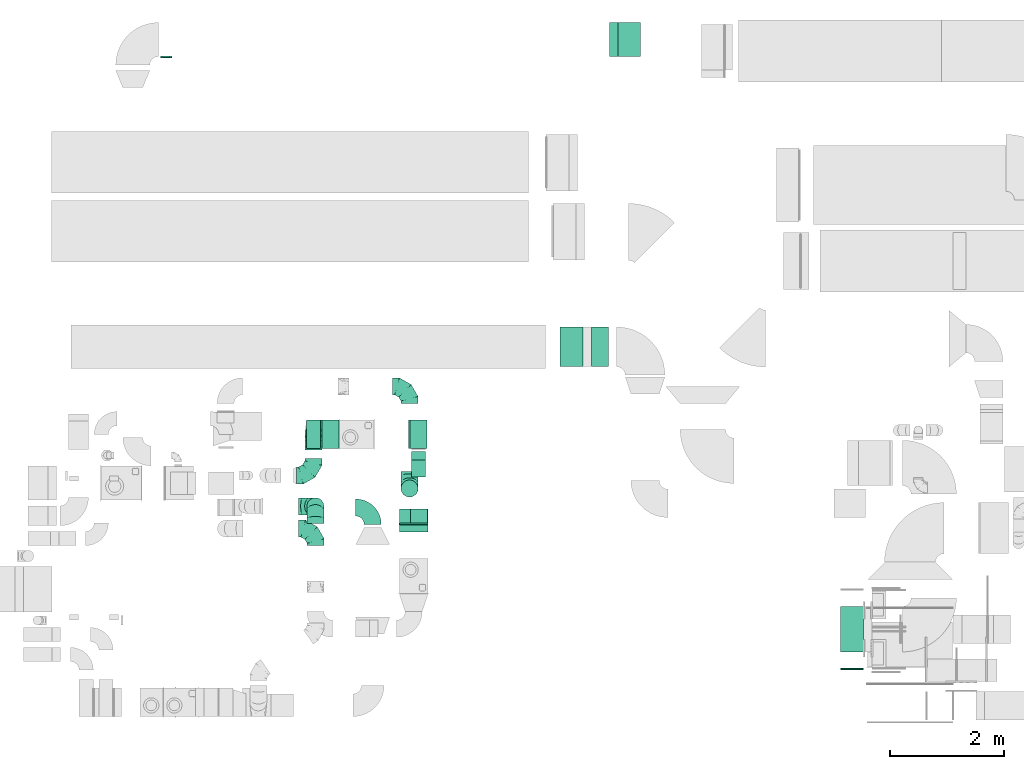
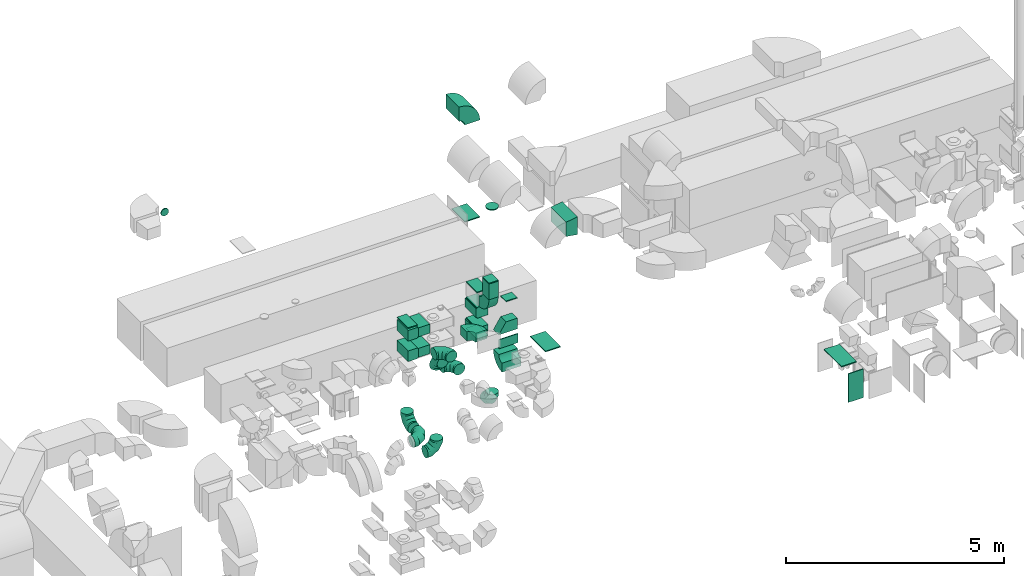
# One storey, part 12 of 59: 31 flow fittings, 1 flow segment.
"""IFC2X3 building model written with IfcOpenShell, lengths in millimetres."""

from ifc_helpers import new_model, entity, si_unit, converted_unit, derived_unit, direction, frame, frame_2d, origin, origin_2d_with_axis, place, context, subcontext, project, spatial, polyline, circle_curve, parameter, trimmed, segment, composite_curve, rectangle, circle, outline, extrude, faceted_brep, source, transform, mapped, material, type_object, type_shapes, element, save


model = new_model("IFC2X3")

# Units and contexts
model_context = context("Model", 3, precision=0.01, world=origin(), true_north=direction((6.12303176911189e-17, 1.0)))
body_context = subcontext(model_context, "Body", "Model", "MODEL_VIEW")
ifc_project = project(units=[si_unit("LENGTHUNIT", "METRE", prefix="MILLI"), si_unit("AREAUNIT", "SQUARE_METRE"), si_unit("VOLUMEUNIT", "CUBIC_METRE"), converted_unit("PLANEANGLEUNIT", "DEGREE", entity("IfcRatioMeasure", 0.0174532925199433), si_unit("PLANEANGLEUNIT", "RADIAN"), dimensions=[0, 0, 0, 0, 0, 0, 0]), si_unit("MASSUNIT", "GRAM", prefix="KILO"), derived_unit("MASSDENSITYUNIT", [(si_unit("MASSUNIT", "GRAM", prefix="KILO"), 1), (si_unit("LENGTHUNIT", "METRE"), -3)]), derived_unit("MOMENTOFINERTIAUNIT", [(si_unit("LENGTHUNIT", "METRE"), 4)]), si_unit("TIMEUNIT", "SECOND"), si_unit("FREQUENCYUNIT", "HERTZ"), si_unit("THERMODYNAMICTEMPERATUREUNIT", "DEGREE_CELSIUS"), derived_unit("THERMALTRANSMITTANCEUNIT", [(si_unit("MASSUNIT", "GRAM", prefix="KILO"), 1), (si_unit("THERMODYNAMICTEMPERATUREUNIT", "KELVIN"), -1), (si_unit("TIMEUNIT", "SECOND"), -3)]), derived_unit("VOLUMETRICFLOWRATEUNIT", [(si_unit("LENGTHUNIT", "METRE"), 3), (si_unit("TIMEUNIT", "SECOND"), -1)]), derived_unit("MASSFLOWRATEUNIT", [(si_unit("MASSUNIT", "GRAM", prefix="KILO"), 1), (si_unit("TIMEUNIT", "SECOND"), -1)]), derived_unit("ROTATIONALFREQUENCYUNIT", [(si_unit("TIMEUNIT", "SECOND"), -1)]), si_unit("ELECTRICCURRENTUNIT", "AMPERE"), si_unit("ELECTRICVOLTAGEUNIT", "VOLT"), si_unit("POWERUNIT", "WATT"), si_unit("FORCEUNIT", "NEWTON", prefix="KILO"), si_unit("ILLUMINANCEUNIT", "LUX"), si_unit("LUMINOUSFLUXUNIT", "LUMEN"), si_unit("LUMINOUSINTENSITYUNIT", "CANDELA"), derived_unit("USERDEFINED", [(si_unit("MASSUNIT", "GRAM", prefix="KILO"), -1), (si_unit("LENGTHUNIT", "METRE"), -2), (si_unit("TIMEUNIT", "SECOND"), 3), (si_unit("LUMINOUSFLUXUNIT", "LUMEN"), 1)]), derived_unit("LINEARVELOCITYUNIT", [(si_unit("LENGTHUNIT", "METRE"), 1), (si_unit("TIMEUNIT", "SECOND"), -1)]), si_unit("PRESSUREUNIT", "PASCAL"), derived_unit("USERDEFINED", [(si_unit("LENGTHUNIT", "METRE"), -2), (si_unit("MASSUNIT", "GRAM", prefix="KILO"), 1), (si_unit("TIMEUNIT", "SECOND"), -2)]), derived_unit("LINEARFORCEUNIT", [(si_unit("MASSUNIT", "GRAM", prefix="KILO"), 1), (si_unit("LENGTHUNIT", "METRE"), 1), (si_unit("TIMEUNIT", "SECOND"), -2), (si_unit("LENGTHUNIT", "METRE"), -1)]), derived_unit("PLANARFORCEUNIT", [(si_unit("MASSUNIT", "GRAM", prefix="KILO"), 1), (si_unit("LENGTHUNIT", "METRE"), 1), (si_unit("TIMEUNIT", "SECOND"), -2), (si_unit("LENGTHUNIT", "METRE"), -2)])], contexts=[model_context])

# Site, building, storey
site_placement = place(None, origin())
site = spatial("IfcSite", under=ifc_project, at=site_placement, CompositionType="ELEMENT")
building_placement = place(site_placement, origin())
building = spatial("IfcBuilding", under=site, at=building_placement, CompositionType="ELEMENT")
storey_placement = place(building_placement, frame((0.0, 0.0, 28200.0)))
storey = spatial("IfcBuildingStorey", under=building, at=storey_placement, CompositionType="ELEMENT", Elevation=28200.0)

# Flow segment
duct_segment_type = type_object("IfcDuctSegmentType", PredefinedType="NOTDEFINED")
flow_segment_placement = place(storey_placement, frame((34404.03, 12149.6, 3765.0)))
element("IfcFlowSegment", 1, at=flow_segment_placement, inside=storey, type_object=duct_segment_type, context=body_context, shape_type="SweptSolid", body=[
    extrude(rectangle(XDim=300.000000000001, YDim=249.999999999999, at=origin_2d_with_axis()), frame((125.0, 150.0, 0.0), z_axis=(0.0, 0.0, 1.0), x_axis=(0.0, 1.0, 0.0)), (0.0, 0.0, 1.0), 440.000024999958),
])

# Flow fittings
ifc_material = material()
duct_fitting_type_1 = type_object("IfcDuctFittingType", PredefinedType="NOTDEFINED", material=ifc_material)
shared_shape_1 = source(origin(), body_context, "Body", "SweptSolid", [
    extrude(rectangle(XDim=24.9999999999999, YDim=400.0, at=origin_2d_with_axis()), frame((12.5, 0.0, -300.0)), (0.0, 0.0, 1.0), 600.0),
])
type_shapes(duct_fitting_type_1, [shared_shape_1])
flow_fitting_1_placement = place(storey_placement, frame((38240.11, 19854.6, 196.21), z_axis=(0.0, -1.0, 0.0), x_axis=(0.0, 0.0, -1.0)))
element("IfcFlowFitting", 2, at=flow_fitting_1_placement, inside=storey, type_object=duct_fitting_type_1, material=ifc_material, context=body_context, shape_type="MappedRepresentation", body=[
    mapped(shared_shape_1, transform((0.0, 0.0, 0.0), scale=1.0)),
])
duct_fitting_type_2 = type_object("IfcDuctFittingType", PredefinedType="NOTDEFINED", material=ifc_material)
shared_shape_2 = source(origin(), body_context, "Body", "SweptSolid", [
    extrude(rectangle(XDim=24.9999999999999, YDim=400.0, at=origin_2d_with_axis()), frame((12.5, 0.0, -350.0)), (0.0, 0.0, 1.0), 700.0),
])
type_shapes(duct_fitting_type_2, [shared_shape_2])
flow_fitting_2_placement = place(storey_placement, frame((37223.99, 14444.6, 230.0), z_axis=(0.0, -1.0, 0.0), x_axis=(0.0, 0.0, -1.0)))
element("IfcFlowFitting", 3, at=flow_fitting_2_placement, inside=storey, type_object=duct_fitting_type_2, material=ifc_material, context=body_context, shape_type="MappedRepresentation", body=[
    mapped(shared_shape_2, transform((0.0, 0.0, 0.0), scale=1.0)),
])
duct_fitting_type_3 = type_object("IfcDuctFittingType", PredefinedType="NOTDEFINED", material=ifc_material)
shared_shape_3 = source(origin(), body_context, "Body", "SweptSolid", [
    extrude(outline(polyline([(-115.08, -221.94), (189.06, -221.94), (106.86, 271.26), (-180.84, 172.62), (-115.08, -221.94)])), frame((150.0, -350.0, 0.0), z_axis=(0.0, 1.0, 0.0), x_axis=(0.986393923832159, 0.0, 0.164398987305264)), (0.0, 0.0, 1.0), 700.0),
])
type_shapes(duct_fitting_type_3, [shared_shape_3])
flow_fitting_3_placement = place(storey_placement, frame((37573.99, 14444.6, 3450.0)))
element("IfcFlowFitting", 4, at=flow_fitting_3_placement, inside=storey, type_object=duct_fitting_type_3, material=ifc_material, context=body_context, shape_type="MappedRepresentation", body=[
    mapped(shared_shape_3, transform((0.0, 0.0, 0.0), scale=1.0)),
])
duct_fitting_type_4 = type_object("IfcDuctFittingType", PredefinedType="NOTDEFINED", material=ifc_material)
shared_shape_4 = source(origin(), body_context, "Body", "SweptSolid", [
    extrude(rectangle(XDim=26.0960000000177, YDim=250.0, at=origin_2d_with_axis()), frame((6.95, 0.0, -250.0)), (0.0, 0.0, 1.0), 500.0),
])
type_shapes(duct_fitting_type_4, [shared_shape_4])
flow_fitting_4_placement = place(storey_placement, frame((34445.98, 11335.54, 3100.0), z_axis=(-1.0, 0.0, 0.0), x_axis=(0.0, -1.0, 0.0)))
element("IfcFlowFitting", 5, at=flow_fitting_4_placement, inside=storey, type_object=duct_fitting_type_4, material=ifc_material, context=body_context, shape_type="MappedRepresentation", body=[
    mapped(shared_shape_4, transform((0.0, 0.0, 0.0), scale=1.0)),
])
duct_fitting_type_5 = type_object("IfcDuctFittingType", PredefinedType="NOTDEFINED", material=ifc_material)
shared_shape_5 = source(origin(), body_context, "Body", "SweptSolid", [
    extrude(outline(polyline([(-154.94, -199.94), (145.15, -199.94), (152.49, 99.97), (-142.71, 299.91), (-154.94, -199.94)])), frame((150.0, -125.0, 46.33), z_axis=(0.0, 1.0, 0.0), x_axis=(0.999701032994285, 0.0, -0.0244508615422689)), (0.0, 0.0, 1.0), 250.0),
])
type_shapes(duct_fitting_type_5, [shared_shape_5])
flow_fitting_5_placement = place(storey_placement, frame((34445.98, 11460.54, 3349.26), z_axis=(1.0, 0.0, 0.0), x_axis=(0.0, 0.0, 1.0)))
element("IfcFlowFitting", 6, at=flow_fitting_5_placement, inside=storey, type_object=duct_fitting_type_5, material=ifc_material, context=body_context, shape_type="MappedRepresentation", body=[
    mapped(shared_shape_5, transform((0.0, 0.0, 0.0), scale=1.0)),
])
duct_fitting_type_6 = type_object("IfcDuctFittingType", PredefinedType="NOTDEFINED", material=ifc_material)
shared_shape_6 = source(origin(), body_context, "Body", "SweptSolid", [
    extrude(rectangle(XDim=24.9999999999999, YDim=400.0, at=origin_2d_with_axis()), frame((12.5, 0.0, -400.0)), (0.0, 0.0, 1.0), 800.0),
])
type_shapes(duct_fitting_type_6, [shared_shape_6])
flow_fitting_6_placement = place(storey_placement, frame((42165.03, 8785.16, 700.0), z_axis=(0.0, 0.0, 1.0), x_axis=(0.0, -1.0, 0.0)))
element("IfcFlowFitting", 7, at=flow_fitting_6_placement, inside=storey, type_object=duct_fitting_type_6, material=ifc_material, context=body_context, shape_type="MappedRepresentation", body=[
    mapped(shared_shape_6, transform((0.0, 0.0, 0.0), scale=1.0)),
])
duct_fitting_type_7 = type_object("IfcDuctFittingType", PredefinedType="NOTDEFINED", material=ifc_material)
shared_shape_7 = source(origin(), body_context, "Body", "SweptSolid", [
    extrude(rectangle(XDim=24.9999999999999, YDim=250.0, at=origin_2d_with_axis()), frame((12.5, 0.0, -250.0)), (0.0, 0.0, 1.0), 500.0),
])
type_shapes(duct_fitting_type_7, [shared_shape_7])
flow_fitting_7_placement = place(storey_placement, frame((32680.82, 12904.98, 3300.0), z_axis=(0.0, 1.0, 0.0), x_axis=(0.0, 0.0, 1.0)))
element("IfcFlowFitting", 8, at=flow_fitting_7_placement, inside=storey, type_object=duct_fitting_type_7, material=ifc_material, context=body_context, shape_type="MappedRepresentation", body=[
    mapped(shared_shape_7, transform((0.0, 0.0, 0.0), scale=1.0)),
])
duct_fitting_type_8 = type_object("IfcDuctFittingType", PredefinedType="NOTDEFINED", material=ifc_material)
shared_shape_8 = source(origin(), body_context, "Body", "SweptSolid", [
    extrude(outline(polyline([(-150.0, 56.25), (-150.0, -193.75), (150.0, -193.75), (150.0, 56.25), (125.0, 56.25), (125.0, 81.25), (-125.0, 81.25), (-125.0, 56.25), (-150.0, 56.25)])), frame((0.0, -68.75, -250.0), z_axis=(0.0, 0.0, -1.0), x_axis=(1.0, 0.0, 0.0)), (0.0, 0.0, -1.0), 500.0),
])
type_shapes(duct_fitting_type_8, [shared_shape_8])
for number, where, z_axis, x_axis in (
    (9, (32680.82, 12904.98, 2525.0), (0.0, 1.0, 0.0), (0.0, 0.0, -1.0)),
    (10, (32680.82, 12904.98, 3100.0), (0.0, 1.0, 0.0), (0.0, 0.0, -1.0)),
):
    element("IfcFlowFitting", number, at=place(storey_placement, frame(where, z_axis=z_axis, x_axis=x_axis)), inside=storey, type_object=duct_fitting_type_8, material=ifc_material, context=body_context, shape_type="MappedRepresentation", body=[
        mapped(shared_shape_8, transform((0.0, 0.0, 0.0), scale=1.0)),
    ])
duct_fitting_type_9 = type_object("IfcDuctFittingType", PredefinedType="NOTDEFINED", material=ifc_material)
shared_shape_9 = source(origin(), body_context, "Body", "SweptSolid", [
    extrude(rectangle(XDim=300.0, YDim=500.0, at=origin_2d_with_axis()), frame((150.0, 0.0, -125.0)), (0.0, 0.0, 1.0), 250.0),
])
type_shapes(duct_fitting_type_9, [shared_shape_9])
for number, where in (
    (11, (32830.82, 12904.98, 3100.0)),
    (12, (32830.82, 12904.98, 2525.0)),
):
    element("IfcFlowFitting", number, at=place(storey_placement, frame(where)), inside=storey, type_object=duct_fitting_type_9, material=ifc_material, context=body_context, shape_type="MappedRepresentation", body=[
        mapped(shared_shape_9, transform((0.0, 0.0, 0.0), scale=1.0)),
    ])
duct_fitting_type_10 = type_object("IfcDuctFittingType", PredefinedType="NOTDEFINED", material=ifc_material)
shared_shape_10 = source(origin(), body_context, "Body", "SweptSolid", [
    extrude(outline(polyline([(-150.0, 68.75), (-150.0, -231.25), (150.0, -231.25), (150.0, 68.75), (125.0, 68.75), (125.0, 93.75), (-125.0, 93.75), (-125.0, 68.75), (-150.0, 68.75)])), frame((0.0, -81.25, -250.0), z_axis=(0.0, 0.0, -1.0), x_axis=(1.0, 0.0, 0.0)), (0.0, 0.0, -1.0), 500.0),
])
type_shapes(duct_fitting_type_10, [shared_shape_10])
for number, where, z_axis, x_axis in (
    (13, (34529.03, 12904.98, 2525.0), (0.0, 1.0, 0.0), (0.0, 0.0, 1.0)),
    (14, (34529.03, 12904.98, 3100.0), (0.0, 1.0, 0.0), (0.0, 0.0, 1.0)),
):
    element("IfcFlowFitting", number, at=place(storey_placement, frame(where, z_axis=z_axis, x_axis=x_axis)), inside=storey, type_object=duct_fitting_type_10, material=ifc_material, context=body_context, shape_type="MappedRepresentation", body=[
        mapped(shared_shape_10, transform((0.0, 0.0, 0.0), scale=1.0)),
    ])
duct_fitting_type_11 = type_object("IfcDuctFittingType", PredefinedType="NOTDEFINED", material=ifc_material)
shared_shape_11 = source(origin(), body_context, "Body", "SweptSolid", [
    extrude(rectangle(XDim=24.9999999999999, YDim=300.0, at=origin_2d_with_axis()), frame((12.5, 0.0, -250.0)), (0.0, 0.0, 1.0), 500.0),
])
type_shapes(duct_fitting_type_11, [shared_shape_11])
for number, where, z_axis, x_axis in (
    (15, (34529.03, 12904.98, 2375.0), (0.0, 1.0, 0.0), (0.0, 0.0, -1.0)),
    (16, (34529.03, 12904.98, 3655.0), (0.0, -1.0, 0.0), (0.0, 0.0, 1.0)),
):
    element("IfcFlowFitting", number, at=place(storey_placement, frame(where, z_axis=z_axis, x_axis=x_axis)), inside=storey, type_object=duct_fitting_type_11, material=ifc_material, context=body_context, shape_type="MappedRepresentation", body=[
        mapped(shared_shape_11, transform((0.0, 0.0, 0.0), scale=1.0)),
    ])
duct_fitting_type_12 = type_object("IfcDuctFittingType", PredefinedType="NOTDEFINED", material=ifc_material)
shared_shape_12 = source(origin(), body_context, "Body", "SweptSolid", [
    extrude(rectangle(XDim=26.0960000000656, YDim=400.0, at=origin_2d_with_axis()), frame((6.95, 0.0, -400.0)), (0.0, 0.0, 1.0), 800.0),
])
type_shapes(duct_fitting_type_12, [shared_shape_12])
flow_fitting_8_placement = place(storey_placement, frame((42165.03, 9473.67, 1100.0), z_axis=(0.0, 1.0, 0.0), x_axis=(0.0, 0.0, 1.0)))
element("IfcFlowFitting", 17, at=flow_fitting_8_placement, inside=storey, type_object=duct_fitting_type_12, material=ifc_material, context=body_context, shape_type="MappedRepresentation", body=[
    mapped(shared_shape_12, transform((0.0, 0.0, 0.0), scale=1.0)),
])
duct_fitting_type_13 = type_object("IfcDuctFittingType", PredefinedType="NOTDEFINED", material=ifc_material)
shared_shape_13 = source(origin(), body_context, "Body", "SweptSolid", [
    extrude(circle(Radius=149.999999999999, at=origin_2d_with_axis()), frame((0.0, 0.0, 0.0), z_axis=(1.0, 0.0, 0.0), x_axis=(0.0, 1.0, 0.0)), (0.0, 0.0, 1.0), 25.0000000000018),
])
type_shapes(duct_fitting_type_13, [shared_shape_13])
flow_fitting_9_placement = place(storey_placement, frame((34372.78, 11949.59, 6504.78), z_axis=(0.0, 1.0, 0.0), x_axis=(0.0, 0.0, 1.0)))
element("IfcFlowFitting", 18, at=flow_fitting_9_placement, inside=storey, type_object=duct_fitting_type_13, material=ifc_material, context=body_context, shape_type="MappedRepresentation", body=[
    mapped(shared_shape_13, transform((0.0, 0.0, 0.0), scale=1.0)),
])
duct_fitting_type_14 = type_object("IfcDuctFittingType", PredefinedType="NOTDEFINED", material=ifc_material)
shared_shape_14 = source(origin(), body_context, "Body", "SweptSolid", [
    extrude(rectangle(XDim=24.9999999999999, YDim=250.0, at=origin_2d_with_axis()), frame((12.5, 0.0, -150.0)), (0.0, 0.0, 1.0), 300.0),
])
type_shapes(duct_fitting_type_14, [shared_shape_14])
for number, where, z_axis, x_axis in (
    (19, (34529.03, 12299.6, 4205.0), (0.0, 1.0, 0.0), (0.0, 0.0, 1.0)),
    (20, (34538.64, 11460.54, 4205.0), (1.0, 0.0, 0.0), (0.0, 0.0, 1.0)),
):
    element("IfcFlowFitting", number, at=place(storey_placement, frame(where, z_axis=z_axis, x_axis=x_axis)), inside=storey, type_object=duct_fitting_type_14, material=ifc_material, context=body_context, shape_type="MappedRepresentation", body=[
        mapped(shared_shape_14, transform((0.0, 0.0, 0.0), scale=1.0)),
    ])
duct_fitting_type_15 = type_object("IfcDuctFittingType", PredefinedType="NOTDEFINED", material=ifc_material)
shared_shape_15 = source(origin(), body_context, "Body", "Brep", [
    faceted_brep([(20.0, 0.0, -100.0), (20.0, 25.88, -96.59), (20.0, 50.0, -86.6), (20.0, 70.71, -70.71), (20.0, 86.6, -50.0), (20.0, 96.59, -25.88), (20.0, 100.0, 0.0), (20.0, 96.59, 25.88), (20.0, 86.6, 50.0), (20.0, 70.71, 70.71), (20.0, 50.0, 86.6), (20.0, 25.88, 96.59), (20.0, 0.0, 100.0), (20.0, -25.88, 96.59), (20.0, -50.0, 86.6), (20.0, -70.71, 70.71), (20.0, -86.6, 50.0), (20.0, -96.59, 25.88), (20.0, -100.0, 0.0), (20.0, -96.59, -25.88), (20.0, -86.6, -50.0), (20.0, -70.71, -70.71), (20.0, -50.0, -86.6), (20.0, -25.88, -96.59), (0.0, 0.0, 100.0), (-6.1, 0.0, 100.0), (-6.1, -25.88, 96.59), (0.0, -25.88, 96.59), (-6.1, -50.0, 86.6), (0.0, -50.0, 86.6), (0.0, -70.71, 70.71), (-6.1, -70.71, 70.71), (0.0, -86.6, 50.0), (-6.1, -86.6, 50.0), (-6.1, -96.59, 25.88), (0.0, -96.59, 25.88), (-6.1, -100.0, 0.0), (0.0, -100.0, 0.0), (-6.1, -96.59, -25.88), (0.0, -96.59, -25.88), (-6.1, -86.6, -50.0), (0.0, -86.6, -50.0), (0.0, -70.71, -70.71), (-6.1, -70.71, -70.71), (0.0, -50.0, -86.6), (-6.1, -50.0, -86.6), (-6.1, -25.88, -96.59), (0.0, -25.88, -96.59), (-6.1, 0.0, -100.0), (0.0, 0.0, -100.0), (-6.1, 25.88, -96.59), (0.0, 25.88, -96.59), (-6.1, 50.0, -86.6), (0.0, 50.0, -86.6), (0.0, 70.71, -70.71), (-6.1, 70.71, -70.71), (0.0, 86.6, -50.0), (-6.1, 86.6, -50.0), (-6.1, 96.59, -25.88), (0.0, 96.59, -25.88), (-6.1, 100.0, 0.0), (0.0, 100.0, 0.0), (-6.1, 96.59, 25.88), (0.0, 96.59, 25.88), (-6.1, 86.6, 50.0), (0.0, 86.6, 50.0), (0.0, 70.71, 70.71), (-6.1, 70.71, 70.71), (0.0, 50.0, 86.6), (-6.1, 50.0, 86.6), (-6.1, 25.88, 96.59), (0.0, 25.88, 96.59)], [[[0, 1, 2, 3, 4, 5, 6, 7, 8, 9, 10, 11, 12, 13, 14, 15, 16, 17, 18, 19, 20, 21, 22, 23]], [[13, 12, 24, 25, 26, 27]], [[14, 13, 27, 26, 28, 29]], [[30, 15, 14, 29, 28, 31]], [[17, 16, 32, 33, 34, 35]], [[18, 17, 35, 34, 36, 37]], [[32, 16, 15, 30, 31, 33]], [[19, 18, 37, 36, 38, 39]], [[20, 19, 39, 38, 40, 41]], [[42, 21, 20, 41, 40, 43]], [[23, 22, 44, 45, 46, 47]], [[0, 23, 47, 46, 48, 49]], [[44, 22, 21, 42, 43, 45]], [[1, 0, 49, 48, 50, 51]], [[2, 1, 51, 50, 52, 53]], [[54, 3, 2, 53, 52, 55]], [[5, 4, 56, 57, 58, 59]], [[6, 5, 59, 58, 60, 61]], [[56, 4, 3, 54, 55, 57]], [[7, 6, 61, 60, 62, 63]], [[8, 7, 63, 62, 64, 65]], [[66, 9, 8, 65, 64, 67]], [[11, 10, 68, 69, 70, 71]], [[12, 11, 71, 70, 25, 24]], [[68, 10, 9, 66, 67, 69]], [[46, 45, 43, 40, 38, 36, 34, 33, 31, 28, 26, 25, 70, 69, 67, 64, 62, 60, 58, 57, 55, 52, 50, 48]]]),
])
type_shapes(duct_fitting_type_15, [shared_shape_15])
flow_fitting_10_placement = place(storey_placement, frame((30089.23, 19554.6, 3250.0), z_axis=(0.0, 0.0, -1.0), x_axis=(0.0, -1.0, 0.0)))
element("IfcFlowFitting", 21, at=flow_fitting_10_placement, inside=storey, type_object=duct_fitting_type_15, material=ifc_material, context=body_context, shape_type="MappedRepresentation", body=[
    mapped(shared_shape_15, transform((0.0, 0.0, 0.0), scale=1.0)),
])
duct_fitting_type_16 = type_object("IfcDuctFittingType", PredefinedType="NOTDEFINED", material=ifc_material)
shared_shape_16 = source(origin(), body_context, "Body", "Brep", [
    faceted_brep([(-300.0, 0.0, -150.0), (-300.0, -38.82, -144.89), (-300.0, -75.0, -129.9), (-300.0, -106.07, -106.07), (-300.0, -129.9, -75.0), (-300.0, -144.89, -38.82), (-300.0, -150.0, 0.0), (-300.0, -144.89, 38.82), (-300.0, -129.9, 75.0), (-300.0, -106.07, 106.07), (-300.0, -75.0, 129.9), (-300.0, -38.82, 144.89), (-300.0, 0.0, 150.0), (-300.0, 38.82, 144.89), (-300.0, 75.0, 129.9), (-300.0, 106.07, 106.07), (-300.0, 129.9, 75.0), (-300.0, 144.89, 38.82), (-300.0, 150.0, 0.0), (-300.0, 144.89, -38.82), (-300.0, 129.9, -75.0), (-300.0, 106.07, -106.07), (-300.0, 75.0, -129.9), (-300.0, 38.82, -144.89), (-230.02, 38.82, 144.89), (-239.71, 75.0, 129.9), (-219.62, 0.0, 150.0), (-248.04, 106.07, 106.07), (-258.44, 144.89, 38.82), (-259.81, 150.0, 0.0), (-254.42, 129.9, 75.0), (-254.42, 129.9, -75.0), (-248.04, 106.07, -106.07), (-258.44, 144.89, -38.82), (-230.02, 38.82, -144.89), (-219.62, 0.0, -150.0), (-239.71, 75.0, -129.9), (-209.21, -38.82, -144.89), (-199.52, -75.0, -129.9), (-191.19, -106.07, -106.07), (-184.81, -129.9, -75.0), (-180.79, -144.89, -38.82), (-179.42, -150.0, 0.0), (-180.79, -144.89, 38.82), (-184.81, -129.9, 75.0), (-191.19, -106.07, 106.07), (-199.52, -75.0, 129.9), (-209.21, -38.82, 144.89), (-108.81, 108.81, 144.89), (-135.29, 135.29, 129.9), (-80.38, 80.38, 150.0), (-158.03, 158.03, 106.07), (-175.48, 175.48, 75.0), (-186.45, 186.45, 38.82), (-190.19, 190.19, 0.0), (-186.45, 186.45, -38.82), (-175.48, 175.48, -75.0), (-158.03, 158.03, -106.07), (-108.81, 108.81, -144.89), (-80.38, 80.38, -150.0), (-135.29, 135.29, -129.9), (-51.96, 51.96, -144.89), (-25.48, 25.48, -129.9), (-2.74, 2.74, -106.07), (14.71, -14.71, -75.0), (25.68, -25.68, -38.82), (29.42, -29.42, 0.0), (25.68, -25.68, 38.82), (14.71, -14.71, 75.0), (-2.74, 2.74, 106.07), (-25.48, 25.48, 129.9), (-51.96, 51.96, 144.89), (-38.82, 230.02, 144.89), (-75.0, 239.71, 129.9), (0.0, 219.62, 150.0), (-106.07, 248.04, 106.07), (-129.9, 254.42, 75.0), (-144.89, 258.44, 38.82), (-150.0, 259.81, 0.0), (-144.89, 258.44, -38.82), (-129.9, 254.42, -75.0), (-106.07, 248.04, -106.07), (-38.82, 230.02, -144.89), (0.0, 219.62, -150.0), (-75.0, 239.71, -129.9), (38.82, 209.21, -144.89), (75.0, 199.52, -129.9), (106.07, 191.19, -106.07), (129.9, 184.81, -75.0), (144.89, 180.79, -38.82), (150.0, 179.42, 0.0), (144.89, 180.79, 38.82), (129.9, 184.81, 75.0), (106.07, 191.19, 106.07), (75.0, 199.52, 129.9), (38.82, 209.21, 144.89), (-150.0, 300.0, 0.0), (-144.89, 300.0, 38.82), (-129.9, 300.0, 75.0), (-106.07, 300.0, 106.07), (-75.0, 300.0, 129.9), (-38.82, 300.0, 144.89), (0.0, 300.0, 150.0), (38.82, 300.0, 144.89), (75.0, 300.0, 129.9), (106.07, 300.0, 106.07), (129.9, 300.0, 75.0), (144.89, 300.0, 38.82), (150.0, 300.0, 0.0), (144.89, 300.0, -38.82), (129.9, 300.0, -75.0), (106.07, 300.0, -106.07), (75.0, 300.0, -129.9), (38.82, 300.0, -144.89), (0.0, 300.0, -150.0), (-38.82, 300.0, -144.89), (-75.0, 300.0, -129.9), (-106.07, 300.0, -106.07), (-129.9, 300.0, -75.0), (-144.89, 300.0, -38.82)], [[[0, 1, 2, 3, 4, 5, 6, 7, 8, 9, 10, 11, 12, 13, 14, 15, 16, 17, 18, 19, 20, 21, 22, 23]], [[24, 25, 14, 13]], [[26, 24, 13, 12]], [[14, 25, 27, 15]], [[28, 29, 18, 17]], [[30, 28, 17, 16]], [[15, 27, 30, 16]], [[20, 31, 32, 21]], [[33, 31, 20, 19]], [[18, 29, 33, 19]], [[34, 35, 0, 23]], [[36, 34, 23, 22]], [[32, 36, 22, 21]], [[1, 0, 35, 37]], [[2, 1, 37, 38]], [[38, 39, 3, 2]], [[5, 4, 40, 41]], [[6, 5, 41, 42]], [[39, 40, 4, 3]], [[6, 42, 43, 7]], [[7, 43, 44, 8]], [[8, 44, 45, 9]], [[9, 45, 46, 10]], [[10, 46, 47, 11]], [[26, 12, 11, 47]], [[48, 49, 25, 24]], [[50, 48, 24, 26]], [[27, 25, 49, 51]], [[52, 53, 28, 30]], [[51, 52, 30, 27]], [[29, 28, 53, 54]], [[55, 56, 31, 33]], [[54, 55, 33, 29]], [[32, 31, 56, 57]], [[58, 59, 35, 34]], [[60, 58, 34, 36]], [[57, 60, 36, 32]], [[37, 35, 59, 61]], [[38, 37, 61, 62]], [[39, 38, 62, 63]], [[41, 40, 64, 65]], [[42, 41, 65, 66]], [[63, 64, 40, 39]], [[43, 42, 66, 67]], [[44, 43, 67, 68]], [[68, 69, 45, 44]], [[46, 45, 69, 70]], [[47, 46, 70, 71]], [[26, 47, 71, 50]], [[72, 73, 49, 48]], [[74, 72, 48, 50]], [[51, 49, 73, 75]], [[76, 77, 53, 52]], [[75, 76, 52, 51]], [[54, 53, 77, 78]], [[79, 80, 56, 55]], [[78, 79, 55, 54]], [[57, 56, 80, 81]], [[82, 83, 59, 58]], [[84, 82, 58, 60]], [[81, 84, 60, 57]], [[61, 59, 83, 85]], [[62, 61, 85, 86]], [[63, 62, 86, 87]], [[65, 64, 88, 89]], [[66, 65, 89, 90]], [[87, 88, 64, 63]], [[67, 66, 90, 91]], [[68, 67, 91, 92]], [[92, 93, 69, 68]], [[70, 69, 93, 94]], [[71, 70, 94, 95]], [[50, 71, 95, 74]], [[96, 97, 98, 99, 100, 101, 102, 103, 104, 105, 106, 107, 108, 109, 110, 111, 112, 113, 114, 115, 116, 117, 118, 119]], [[101, 100, 73, 72]], [[102, 101, 72, 74]], [[75, 73, 100, 99]], [[77, 76, 98, 97]], [[78, 77, 97, 96]], [[99, 98, 76, 75]], [[119, 118, 80, 79]], [[96, 119, 79, 78]], [[117, 81, 80, 118]], [[84, 116, 115, 82]], [[82, 115, 114, 83]], [[116, 84, 81, 117]], [[83, 114, 113, 85]], [[85, 113, 112, 86]], [[111, 87, 86, 112]], [[88, 110, 109, 89]], [[89, 109, 108, 90]], [[110, 88, 87, 111]], [[91, 90, 108, 107]], [[92, 91, 107, 106]], [[106, 105, 93, 92]], [[95, 94, 104, 103]], [[74, 95, 103, 102]], [[105, 104, 94, 93]]]),
])
type_shapes(duct_fitting_type_16, [shared_shape_16])
flow_fitting_11_placement = place(storey_placement, frame((32720.0, 11244.5, 3500.0), z_axis=(0.0, 0.0, 1.0), x_axis=(0.0, 1.0, 0.0)))
element("IfcFlowFitting", 22, at=flow_fitting_11_placement, inside=storey, type_object=duct_fitting_type_16, material=ifc_material, context=body_context, shape_type="MappedRepresentation", body=[
    mapped(shared_shape_16, transform((0.0, 0.0, 0.0), scale=1.0)),
])
duct_fitting_type_17 = type_object("IfcDuctFittingType", PredefinedType="NOTDEFINED", material=ifc_material)
type_shapes(duct_fitting_type_17, [shared_shape_16])
for number, where, z_axis, x_axis in (
    (23, (32715.69, 11637.41, 3100.0), (-1.0, 0.0, 0.0), (0.0, 1.0, 0.0)),
    (24, (32715.69, 11637.41, 520.0), (0.0, 1.0, 0.0), (0.0, 0.0, -1.0)),
    (25, (34372.78, 13749.59, 1044.78), (0.0, 0.0, 1.0), (0.0, 1.0, 0.0)),
    (26, (34372.78, 11949.59, 1044.78), (-1.0, 0.0, 0.0), (0.0, -1.0, 0.0)),
):
    element("IfcFlowFitting", number, at=place(storey_placement, frame(where, z_axis=z_axis, x_axis=x_axis)), inside=storey, type_object=duct_fitting_type_17, material=ifc_material, context=body_context, shape_type="MappedRepresentation", body=[
        mapped(shared_shape_16, transform((0.0, 0.0, 0.0), scale=1.0)),
    ])
flow_fitting_12_placement = place(storey_placement, frame((32680.82, 12178.65, 500.0)))
element("IfcFlowFitting", 27, at=flow_fitting_12_placement, inside=storey, type_object=duct_fitting_type_17, material=ifc_material, context=body_context, shape_type="MappedRepresentation", body=[
    mapped(shared_shape_16, transform((0.0, 0.0, 0.0), scale=1.0)),
])
flow_fitting_13_placement = place(storey_placement, frame((32680.82, 12924.09, 500.0), z_axis=(1.0, 0.0, 0.0), x_axis=(0.0, 1.0, 0.0)))
element("IfcFlowFitting", 28, at=flow_fitting_13_placement, inside=storey, type_object=duct_fitting_type_17, material=ifc_material, context=body_context, shape_type="MappedRepresentation", body=[
    mapped(shared_shape_16, transform((0.0, 0.0, 0.0), scale=1.0)),
])
duct_fitting_type_18 = type_object("IfcDuctFittingType", PredefinedType="NOTDEFINED", material=ifc_material)
shared_shape_17 = source(origin(), body_context, "Body", "SweptSolid", [
    extrude(outline(composite_curve([segment(polyline([(-300.0, -150.0), (0.0, -150.0)]), True, "CONTINUOUS"), segment(trimmed(circle_curve(frame_2d((150.0, -150.0), x_axis=(0.0, 1.0)), 150.0), [parameter(0.0)], [parameter(90.0)], True, "PARAMETER"), False, "CONTINUOUS"), segment(polyline([(150.0, 0.0), (150.0, 300.0)]), True, "CONTINUOUS"), segment(trimmed(circle_curve(frame_2d((150.0, -150.0), x_axis=(0.0, 1.0)), 450.0), [parameter(0.0)], [parameter(90.0000000000001)], True, "PARAMETER"), True, "CONTINUOUS")], self_intersect=False)), frame((-150.0, 150.0, -125.0), z_axis=(0.0, 0.0, 1.0), x_axis=(-1.0, 0.0, 0.0)), (0.0, 0.0, 1.0), 250.0),
])
type_shapes(duct_fitting_type_18, [shared_shape_17])
for number, where, z_axis, x_axis in (
    (29, (33725.03, 11614.96, 3500.0), (0.0, -3.42825393043104e-08, 1.0), (0.0, 1.0, 3.42825393043104e-08)),
    (30, (34529.03, 12299.6, 3465.0), (1.0, 0.0, 0.0), (0.0, 0.0, -1.0)),
):
    element("IfcFlowFitting", number, at=place(storey_placement, frame(where, z_axis=z_axis, x_axis=x_axis)), inside=storey, type_object=duct_fitting_type_18, material=ifc_material, context=body_context, shape_type="MappedRepresentation", body=[
        mapped(shared_shape_17, transform((0.0, 0.0, 0.0), scale=1.0)),
    ])
duct_fitting_type_19 = type_object("IfcDuctFittingType", PredefinedType="NOTDEFINED", material=ifc_material)
shared_shape_18 = source(origin(), body_context, "Body", "SweptSolid", [
    extrude(outline(composite_curve([segment(polyline([(-262.5, -137.5), (-12.5, -137.5)]), True, "CONTINUOUS"), segment(trimmed(circle_curve(frame_2d((137.5, -137.5), x_axis=(0.0, 1.0)), 150.0), [parameter(0.0)], [parameter(90.0000000000001)], True, "PARAMETER"), False, "CONTINUOUS"), segment(polyline([(137.5, 12.5), (137.5, 262.5)]), True, "CONTINUOUS"), segment(trimmed(circle_curve(frame_2d((137.5, -137.5), x_axis=(0.0, 1.0)), 400.0), [parameter(0.0)], [parameter(90.0000000000001)], True, "PARAMETER"), True, "CONTINUOUS")], self_intersect=False)), frame((-137.5, 137.5, -250.0), z_axis=(0.0, 0.0, 1.0), x_axis=(-1.0, 0.0, 0.0)), (0.0, 0.0, 1.0), 500.0),
])
type_shapes(duct_fitting_type_19, [shared_shape_18])
flow_fitting_14_placement = place(storey_placement, frame((34445.98, 11460.54, 2525.0), z_axis=(-1.0, 0.0, 0.0), x_axis=(0.0, 0.0, -1.0)))
element("IfcFlowFitting", 31, at=flow_fitting_14_placement, inside=storey, type_object=duct_fitting_type_19, material=ifc_material, context=body_context, shape_type="MappedRepresentation", body=[
    mapped(shared_shape_18, transform((0.0, 0.0, 0.0), scale=1.0)),
])
duct_fitting_type_20 = type_object("IfcDuctFittingType", PredefinedType="NOTDEFINED", material=ifc_material)
shared_shape_19 = source(origin(), body_context, "Body", "SweptSolid", [
    extrude(outline(composite_curve([segment(polyline([(-375.0, -175.0), (25.0, -175.0)]), True, "CONTINUOUS"), segment(trimmed(circle_curve(frame_2d((175.0, -175.0), x_axis=(0.0, 1.0)), 150.0), [parameter(0.0)], [parameter(90.0000000000001)], True, "PARAMETER"), False, "CONTINUOUS"), segment(polyline([(175.0, -25.0), (175.0, 375.0)]), True, "CONTINUOUS"), segment(trimmed(circle_curve(frame_2d((175.0, -175.0), x_axis=(0.0, 1.0)), 550.0), [parameter(0.0)], [parameter(90.0)], True, "PARAMETER"), True, "CONTINUOUS")], self_intersect=False)), frame((-175.0, 175.0, -300.0), z_axis=(0.0, 0.0, 1.0), x_axis=(-1.0, 0.0, 0.0)), (0.0, 0.0, 1.0), 600.0),
])
type_shapes(duct_fitting_type_20, [shared_shape_19])
flow_fitting_15_placement = place(storey_placement, frame((38240.11, 19854.6, 3250.0), z_axis=(0.0, -1.0, 0.0), x_axis=(0.0, 0.0, 1.0)))
element("IfcFlowFitting", 32, at=flow_fitting_15_placement, inside=storey, type_object=duct_fitting_type_20, material=ifc_material, context=body_context, shape_type="MappedRepresentation", body=[
    mapped(shared_shape_19, transform((0.0, 0.0, 0.0), scale=1.0)),
])

save(model, "model.ifc")
